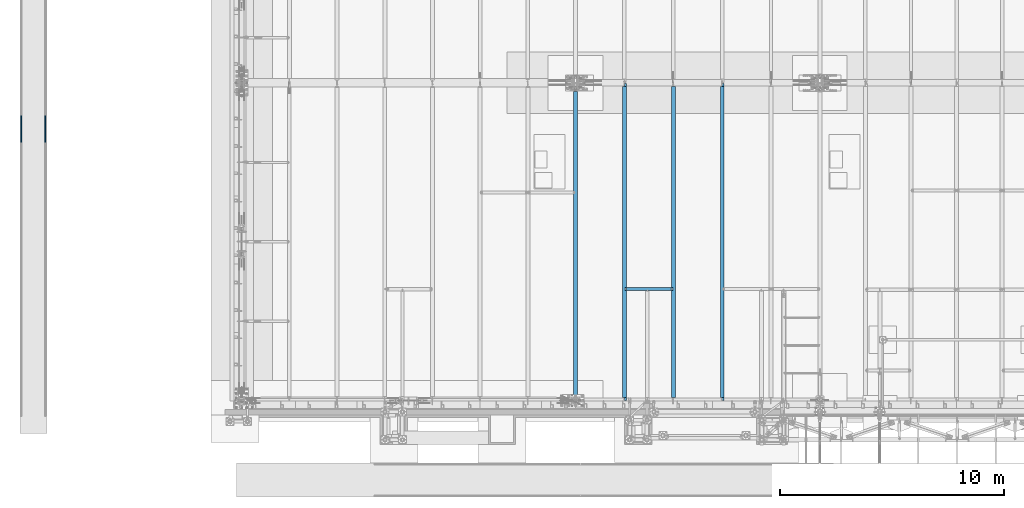
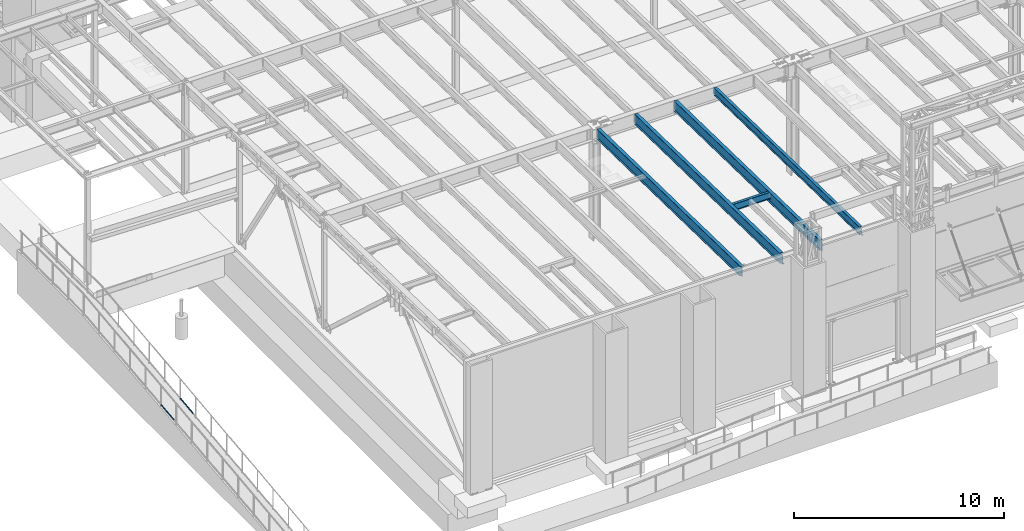
# One storey, part 1041 of 1763: 7 beams, 7 elements without a shape of their own.
"""IFC2X3 building model written with IfcOpenShell, lengths in millimetres."""

from ifc_helpers import new_model, si_unit, frame, origin_with_axes, place, context, subcontext, project, spatial, faceted_brep, material, type_object, element, aggregate, save


model = new_model("IFC2X3")

# Units and contexts
model_context = context("Model", 3, precision=1e-05, world=origin_with_axes())
body_context = subcontext(model_context, "Body", "Model", "MODEL_VIEW")
ifc_project = project(units=[si_unit("LENGTHUNIT", "METRE", prefix="MILLI"), si_unit("AREAUNIT", "SQUARE_METRE"), si_unit("VOLUMEUNIT", "CUBIC_METRE"), si_unit("MASSUNIT", "GRAM", prefix="KILO"), si_unit("TIMEUNIT", "SECOND"), si_unit("PLANEANGLEUNIT", "RADIAN"), si_unit("SOLIDANGLEUNIT", "STERADIAN"), si_unit("THERMODYNAMICTEMPERATUREUNIT", "DEGREE_CELSIUS"), si_unit("LUMINOUSINTENSITYUNIT", "LUMEN")], contexts=[model_context])

# Site, building, storey
site_placement = place(None, origin_with_axes())
site = spatial("IfcSite", under=ifc_project, at=site_placement, CompositionType="ELEMENT")
building_placement = place(site_placement, origin_with_axes())
building = spatial("IfcBuilding", under=site, at=building_placement, Name="Undefined", CompositionType="ELEMENT")
storey_placement = place(building_placement, origin_with_axes())
storey = spatial("IfcBuildingStorey", under=building, at=storey_placement, Name="Undefined", CompositionType="ELEMENT", Elevation=0.0)

# Assembly, beam
assembly_1_placement = place(storey_placement, origin_with_axes())
assembly_1 = element("IfcElementAssembly", 1, at=assembly_1_placement, inside=storey, Name="GUARDRAIL", AssemblyPlace="NOTDEFINED", PredefinedType="RIGID_FRAME")
ifc_material_1 = material(Name="STEEL/A513")
beam_type_1 = type_object("IfcBeamType", PredefinedType="NOTDEFINED")
beam_1_placement = place(assembly_1_placement, frame((-97200.6527017878, -2216.29390356327, 5028.74146606881), z_axis=(0.0, -0.114062593029902, 0.993473565260443), x_axis=(0.0, 0.993473565260443, 0.114062593029902)))
beam_1 = element("IfcBeam", 2, at=beam_1_placement, type_object=beam_type_1, material=ifc_material_1, Name="GUARDRAIL", context=body_context, shape_type="Brep", body=[
    faceted_brep([(1212.42937323828, -9.52499999999418, 16.49778394246), (1211.8517215474, -9.52499999999418, 11.466712380322), (1211.56648654196, -7.68349999999919, 13.3082123803215), (1209.73055642268, 0.0, 15.3670000003658), (1210.15342680948, 0.0, 19.0500000003658), (1211.56648654196, 7.68349999999919, 13.3082123803215), (1211.8517215474, 9.52499999999418, 11.466712380321), (1212.42937323828, 9.52499999999418, 16.49778394246), (1227.14132222466, 19.0500000000029, 3.70164343621582e-10), (1218.64737451707, 16.4977839420899, 9.52500000036889), (1216.4601138957, 16.4977839420899, -9.52499999963402), (1215.22541268888, 13.3082123799541, 7.68350000036753), (1216.41553116007, 15.3669999999984, 3.67435859516263e-10), (1213.46102245432, 13.3082123799541, -7.68349999963448), (1209.21857840355, 9.52499999999418, -11.4667123795907), (1208.64092671268, 9.52499999999418, -16.4977839417297), (1208.51047301132, 7.68349999999919, -13.3082123795912), (1206.20177595354, 0.0, -15.3669999996373), (1205.77890556675, 0.0, -19.0499999996364), (1209.21857840355, -9.52499999999418, -11.4667123795916), (1208.64092671268, -9.52499999999418, -16.4977839417297), (1208.51047301132, -7.68349999999919, -13.3082123795912), (1227.14132222466, -19.0500000000029, 3.71073838323355e-10), (1216.4601138957, -16.4977839420899, -9.52499999963402), (1218.64737451707, -16.4977839420899, 9.52500000036889), (1213.46102245432, -13.3082123799541, -7.68349999963448), (1216.41553116007, -15.3669999999984, 3.67435859516263e-10), (1215.22541268888, -13.3082123799541, 7.68350000036753), (0.0, -16.4977839420899, -9.52500000000146), (0.0, -9.52499999999418, -16.4977839420935), (1.45519152283669e-11, 1.81898940354586e-12, -19.0499999999993), (0.0, 9.52499999999418, -16.4977839420935), (0.0, 16.4977839420899, -9.52500000000146), (0.0, 19.0500000000029, 0.0), (0.0, 16.4977839420899, 9.52500000000146), (0.0, 9.52499999999418, 16.4977839420935), (1.45519152283669e-11, 1.81898940354586e-12, 19.0499999999993), (0.0, -9.52499999999418, 16.4977839420935), (0.0, -16.4977839420899, 9.52500000000146), (0.0, -19.0500000000029, 0.0), (3.63797880709171e-12, -13.3082123799541, -7.68349999999737), (3.63797880709171e-12, -7.68349999999919, -13.3082123799522), (3.63797880709171e-12, 0.0, -15.3669999999956), (3.63797880709171e-12, 7.68349999999919, -13.3082123799522), (3.63797880709171e-12, 13.3082123799541, -7.68349999999737), (4.71409293822944e-08, 15.3669999999984, 0.0), (-1.81898940354586e-12, 13.3082123799541, 7.68349999999919), (-3.63797880709171e-12, 7.68349999999919, 13.3082123799531), (-1.81898940354586e-12, 0.0, 15.3669999999966), (-3.63797880709171e-12, -7.68349999999919, 13.3082123799531), (-1.81898940354586e-12, -13.3082123799541, 7.68349999999919), (4.71409293822944e-08, -15.3669999999984, 0.0)], [[[0, 1, 2, 3, 4]], [[4, 3, 5, 6, 7]], [[8, 9, 10]], [[7, 6, 11, 12, 13, 14, 15, 10, 9]], [[16, 17, 18, 15, 14]], [[19, 20, 18, 17, 21]], [[22, 23, 24]], [[24, 23, 20, 19, 25, 26, 27, 1, 0]], [[28, 29, 20, 23]], [[29, 30, 18, 20]], [[30, 31, 15, 18]], [[31, 32, 10, 15]], [[32, 33, 8, 10]], [[33, 34, 9, 8]], [[34, 35, 7, 9]], [[35, 36, 4, 7]], [[36, 37, 0, 4]], [[37, 38, 24, 0]], [[38, 39, 22, 24]], [[39, 28, 23, 22]], [[38, 37, 36, 35, 34, 33, 32, 31, 30, 29, 28, 39], [40, 41, 42, 43, 44, 45, 46, 47, 48, 49, 50, 51]], [[40, 51, 26, 25]], [[21, 41, 40, 25, 19]], [[42, 41, 21, 17]], [[43, 42, 17, 16]], [[44, 43, 16, 14, 13]], [[45, 44, 13, 12]], [[46, 45, 12, 11]], [[5, 47, 46, 11, 6]], [[48, 47, 5, 3]], [[49, 48, 3, 2]], [[50, 49, 2, 1, 27]], [[51, 50, 27, 26]]]),
])
aggregate(assembly_1, [beam_1])

assembly_2_placement = place(storey_placement, origin_with_axes())
assembly_2 = element("IfcElementAssembly", 3, at=assembly_2_placement, inside=storey, Name="GUARDRAIL", AssemblyPlace="NOTDEFINED", PredefinedType="RIGID_FRAME")
beam_2_placement = place(assembly_2_placement, frame((-96133.8527017878, -2216.29390356327, 5028.74146606881), z_axis=(0.0, -0.114062593029902, 0.993473565260443), x_axis=(0.0, 0.993473565260443, 0.114062593029902)))
beam_2 = element("IfcBeam", 4, at=beam_2_placement, type_object=beam_type_1, material=ifc_material_1, Name="GUARDRAIL", context=body_context, shape_type="Brep", body=[
    faceted_brep([(1212.42937323828, -9.52499999999418, 16.49778394246), (1211.8517215474, -9.52499999999418, 11.466712380322), (1211.56648654196, -7.68349999999919, 13.3082123803215), (1209.73055642268, 0.0, 15.3670000003658), (1210.15342680948, 0.0, 19.0500000003658), (1211.56648654196, 7.68349999999919, 13.3082123803215), (1211.8517215474, 9.52499999999418, 11.466712380321), (1212.42937323828, 9.52499999999418, 16.49778394246), (1227.14132222466, 19.0500000000029, 3.70164343621582e-10), (1218.64737451707, 16.4977839420899, 9.52500000036889), (1216.4601138957, 16.4977839420899, -9.52499999963402), (1215.22541268888, 13.3082123799541, 7.68350000036753), (1216.41553116007, 15.3669999999984, 3.67435859516263e-10), (1213.46102245432, 13.3082123799541, -7.68349999963448), (1209.21857840355, 9.52499999999418, -11.4667123795907), (1208.64092671268, 9.52499999999418, -16.4977839417297), (1208.51047301132, 7.68349999999919, -13.3082123795912), (1206.20177595354, 0.0, -15.3669999996373), (1205.77890556675, 0.0, -19.0499999996364), (1209.21857840355, -9.52499999999418, -11.4667123795916), (1208.64092671268, -9.52499999999418, -16.4977839417297), (1208.51047301132, -7.68349999999919, -13.3082123795912), (1227.14132222466, -19.0500000000029, 3.71073838323355e-10), (1216.4601138957, -16.4977839420899, -9.52499999963402), (1218.64737451707, -16.4977839420899, 9.52500000036889), (1213.46102245432, -13.3082123799541, -7.68349999963448), (1216.41553116007, -15.3669999999984, 3.67435859516263e-10), (1215.22541268888, -13.3082123799541, 7.68350000036753), (0.0, -16.4977839420899, -9.52500000000146), (0.0, -9.52499999999418, -16.4977839420935), (1.45519152283669e-11, 1.81898940354586e-12, -19.0499999999993), (0.0, 9.52499999999418, -16.4977839420935), (0.0, 16.4977839420899, -9.52500000000146), (0.0, 19.0500000000029, 0.0), (0.0, 16.4977839420899, 9.52500000000146), (0.0, 9.52499999999418, 16.4977839420935), (1.45519152283669e-11, 1.81898940354586e-12, 19.0499999999993), (0.0, -9.52499999999418, 16.4977839420935), (0.0, -16.4977839420899, 9.52500000000146), (0.0, -19.0500000000029, 0.0), (3.63797880709171e-12, -13.3082123799541, -7.68349999999737), (3.63797880709171e-12, -7.68349999999919, -13.3082123799522), (3.63797880709171e-12, 0.0, -15.3669999999956), (3.63797880709171e-12, 7.68349999999919, -13.3082123799522), (3.63797880709171e-12, 13.3082123799541, -7.68349999999737), (4.71409293822944e-08, 15.3669999999984, 0.0), (-1.81898940354586e-12, 13.3082123799541, 7.68349999999919), (-3.63797880709171e-12, 7.68349999999919, 13.3082123799531), (-1.81898940354586e-12, 0.0, 15.3669999999966), (-3.63797880709171e-12, -7.68349999999919, 13.3082123799531), (-1.81898940354586e-12, -13.3082123799541, 7.68349999999919), (4.71409293822944e-08, -15.3669999999984, 0.0)], [[[0, 1, 2, 3, 4]], [[4, 3, 5, 6, 7]], [[8, 9, 10]], [[7, 6, 11, 12, 13, 14, 15, 10, 9]], [[16, 17, 18, 15, 14]], [[19, 20, 18, 17, 21]], [[22, 23, 24]], [[24, 23, 20, 19, 25, 26, 27, 1, 0]], [[28, 29, 20, 23]], [[29, 30, 18, 20]], [[30, 31, 15, 18]], [[31, 32, 10, 15]], [[32, 33, 8, 10]], [[33, 34, 9, 8]], [[34, 35, 7, 9]], [[35, 36, 4, 7]], [[36, 37, 0, 4]], [[37, 38, 24, 0]], [[38, 39, 22, 24]], [[39, 28, 23, 22]], [[38, 37, 36, 35, 34, 33, 32, 31, 30, 29, 28, 39], [40, 41, 42, 43, 44, 45, 46, 47, 48, 49, 50, 51]], [[40, 51, 26, 25]], [[21, 41, 40, 25, 19]], [[42, 41, 21, 17]], [[43, 42, 17, 16]], [[44, 43, 16, 14, 13]], [[45, 44, 13, 12]], [[46, 45, 12, 11]], [[5, 47, 46, 11, 6]], [[48, 47, 5, 3]], [[49, 48, 3, 2]], [[50, 49, 2, 1, 27]], [[51, 50, 27, 26]]]),
])
aggregate(assembly_2, [beam_2])

assembly_3_placement = place(storey_placement, origin_with_axes())
assembly_3 = element("IfcElementAssembly", 5, at=assembly_3_placement, inside=storey, Name="BEAM", AssemblyPlace="NOTDEFINED", PredefinedType="RIGID_FRAME")
ifc_material_2 = material(Name="STEEL/A992")
beam_type_2 = type_object("IfcBeamType", Name="W16X26", PredefinedType="NOTDEFINED")
beam_3_placement = place(assembly_3_placement, frame((-70311.7172736983, -8739.17542108259, 11900.629892136), z_axis=(0.0, 0.0, 1.0), x_axis=(1.0, 0.0, 0.0)))
beam_3 = element("IfcBeam", 6, at=beam_3_placement, type_object=beam_type_2, material=ifc_material_2, Name="BEAM", ObjectType="W16X26", context=body_context, shape_type="Brep", body=[
    faceted_brep([(2079.3075, -69.8500000000004, 200.025), (2079.3075, -69.8500000000004, 190.5), (2079.3075, -3.17499999999927, 190.5), (2079.3075, -3.17499999999927, 180.715001487702), (2079.3075, 3.17499999999927, 180.715001487702), (2079.3075, 3.17499999999927, 190.5), (2079.3075, 69.8500000000004, 190.5), (2079.3075, 69.8500000000004, 200.025), (2080.27422992259, -3.17499999999927, 175.854921969656), (2080.27422992259, 3.17499999999927, 175.854921969656), (2083.02724382306, -3.17499999999927, 171.734745501502), (2083.02724382306, 3.17499999999927, 171.734745501502), (2087.14742029121, -3.17499999999927, 168.981731601025), (2087.14742029121, 3.17499999999927, 168.981731601025), (2092.00749980926, -3.17499999999927, 168.015001678437), (2092.00749980926, 3.17499999999927, 168.015001678437), (2161.8575, -3.17499999999927, 168.015001678437), (2161.8575, 3.17499999999927, 168.015001678437), (100.012500000012, -69.8500000000004, 200.025), (100.012500000012, 69.8500000000004, 200.025), (100.012500000012, 69.8500000000004, 190.5), (100.012500000012, 3.17499999999927, 190.5), (100.012500000012, 3.17499999999927, 180.715001488035), (100.012500000012, -3.17499999999927, 180.715001488035), (100.012500000012, -3.17499999999927, 190.5), (100.012500000012, -69.8500000000004, 190.5), (99.0457700774205, 3.17499999999927, 175.854921969989), (99.0457700774205, -3.17499999999927, 175.854921969989), (96.2927561769466, 3.17499999999927, 171.734745501835), (96.2927561769466, -3.17499999999927, 171.734745501835), (92.1725797087929, 3.17499999999927, 168.981731601358), (92.1725797087929, -3.17499999999927, 168.981731601358), (87.3125001907465, 3.17499999999927, 168.01500167877), (87.3125001907465, -3.17499999999927, 168.01500167877), (17.4625000000087, 3.17499999999927, 168.01500167877), (17.4625000000087, -3.17499999999927, 168.01500167877), (17.4625000000087, 3.17499999999927, -190.5), (17.4625000000087, 69.8500000000004, -190.5), (17.4625000000087, 69.8500000000004, -200.025), (17.4625000000087, -69.8500000000004, -200.025), (17.4625000000087, -69.8500000000004, -190.5), (17.4625000000087, -3.17499999999927, -190.5), (2161.8575, 3.17499999999927, -190.5), (2161.8575, 69.8500000000004, -190.5), (2161.8575, 69.8500000000004, -200.025), (2161.8575, -69.8500000000004, -200.025), (2161.8575, -69.8500000000004, -190.5), (2161.8575, -3.17499999999927, -190.5)], [[[0, 1, 2, 3, 4, 5, 6, 7]], [[8, 9, 4, 3]], [[10, 11, 9, 8]], [[12, 13, 11, 10]], [[14, 15, 13, 12]], [[16, 17, 15, 14]], [[18, 19, 20, 21, 22, 23, 24, 25]], [[23, 22, 26, 27]], [[27, 26, 28, 29]], [[29, 28, 30, 31]], [[31, 30, 32, 33]], [[33, 32, 34, 35]], [[36, 37, 38, 39, 40, 41, 35, 34]], [[37, 36, 42, 43]], [[38, 37, 43, 44]], [[39, 38, 44, 45]], [[40, 39, 45, 46]], [[41, 40, 46, 47]], [[12, 10, 8, 3, 2, 24, 23, 27, 29, 31, 33, 35, 41, 47, 16, 14]], [[25, 24, 2, 1]], [[18, 25, 1, 0]], [[19, 18, 0, 7]], [[20, 19, 7, 6]], [[21, 20, 6, 5]], [[42, 36, 34, 32, 30, 28, 26, 22, 21, 5, 4, 9, 11, 13, 15, 17]], [[47, 46, 45, 44, 43, 42, 17, 16]]]),
])
aggregate(assembly_3, [beam_3])

assembly_4_placement = place(storey_placement, origin_with_axes())
assembly_4 = element("IfcElementAssembly", 7, at=assembly_4_placement, inside=storey, Name="BEAM", AssemblyPlace="NOTDEFINED", PredefinedType="RIGID_FRAME")
beam_type_3 = type_object("IfcBeamType", Name="W18X35", PredefinedType="NOTDEFINED")
beam_4_placement = place(assembly_4_placement, frame((-65953.0772736983, -13720.7116289294, 11979.324245716), z_axis=(0.0, 0.0209013539966291, 0.999781542838788), x_axis=(0.0, 0.999781542776098, -0.0209013569953182)))
beam_4 = element("IfcBeam", 8, at=beam_4_placement, type_object=beam_type_3, material=ifc_material_2, Name="BEAM", ObjectType="W18X35", context=body_context, shape_type="Brep", body=[
    faceted_brep([(151.560935824949, 4.2686672599084, -214.31250000022), (151.56093582492, 4.26882967424172, -225.425000000228), (29.273643525974, 4.2688137767982, -225.42500000019), (29.0413264561339, 4.26865133224055, -214.31250000018), (151.560926473738, 76.1999999999971, -214.312500000222), (151.560926473736, 76.1999999999971, -225.425000000228), (151.560925824304, 3.96875, 214.312500000124), (151.560925824304, 76.1999999999971, 214.312500000124), (14015.1114866801, 76.1999999999971, 214.312499995558), (14015.1114866801, 3.96875, 214.312499995558), (151.560925824308, -76.1999999999971, 225.425000000132), (151.560925824308, 76.1999999999971, 225.425000000132), (151.560925824293, 3.96875, 187.065001487916), (151.560925824293, -3.96875, 187.065001487916), (151.560925824304, -3.96875, 214.312500000124), (151.560925824304, -76.1999999999971, 214.312500000124), (150.594195901702, 3.96875, 182.204921969858), (150.594195901702, -3.96875, 182.204921969858), (147.841182001217, 3.96875, 178.084745501696), (147.841182001217, -3.96875, 178.084745501696), (143.721005533052, 3.96875, 175.331731601214), (143.721005533052, -3.96875, 175.331731601214), (138.860926014993, 3.96875, 174.365001678625), (138.860926014993, -3.96875, 174.365001678625), (20.915664516624, 3.96875, 174.365001678663), (20.915664516624, -3.96875, 174.365001678663), (29.0413264561339, -3.96875, -214.31250000018), (29.0413264561339, -76.1999999999971, -214.31250000018), (14165.6418872877, -76.1999999999971, -214.312500004837), (14165.6418872877, -3.96875, -214.312500004837), (29.273643525974, -76.1999999999971, -225.42500000019), (14165.8742043575, -76.1999999999971, -225.425000004847), (14015.111475978, 4.2688297624336, -214.312500004788), (14015.111475978, 4.26866734583018, -225.425000004798), (14015.1114709427, 76.1999999999971, -225.425000004796), (14015.1114709427, 76.1999999999971, -214.312500004788), (14165.6418872877, 4.26875000000291, -214.312500004837), (14165.6627009912, 4.26875000000291, -215.308088836937), (14064.0848962425, 4.26875000000291, -217.431666606117), (14064.0196871856, 4.26875000000291, -214.312500004802), (14165.8742043575, 4.26867789952666, -225.425000004847), (14165.6418872877, 3.96875, -214.312500004837), (14157.6489780418, 3.96875, 168.014997741), (14157.6489780418, -3.96875, 168.014997741), (14022.9514069713, -3.96875, 168.981727663589), (14018.8312305032, -3.96875, 171.734741564072), (14016.0782166027, -3.96875, 175.854918032239), (14015.1114866801, -3.96875, 180.714997550294), (14015.1114866801, -3.96875, 214.312499995558), (14027.8114864894, -3.96875, 168.014997740998), (14015.1114866801, -76.1999999999971, 214.312499995558), (14015.1114866801, -76.1999999999971, 225.424999995566), (14015.1114866801, 76.1999999999971, 225.424999995566), (14015.1114866801, 3.96875, 180.714997550294), (14016.0782166027, 3.96875, 175.854918032239), (14018.8312305032, 3.96875, 171.734741564072), (14022.9514069713, 3.96875, 168.981727663589), (14027.8114864894, 3.96875, 168.014997740998), (29.0413264561339, 3.96875, -214.31250000018)], [[[0, 1, 2, 3]], [[4, 5, 1, 0]], [[6, 7, 8, 9]], [[10, 11, 7, 6, 12, 13, 14, 15]], [[13, 12, 16, 17]], [[17, 16, 18, 19]], [[19, 18, 20, 21]], [[21, 20, 22, 23]], [[23, 22, 24, 25]], [[26, 27, 28, 29]], [[27, 30, 31, 28]], [[32, 33, 34, 35]], [[36, 37, 38, 39]], [[37, 40, 33, 32, 39, 38]], [[36, 41, 42, 43, 29, 28, 31, 40, 37]], [[44, 45, 46, 47, 48, 14, 13, 17, 19, 21, 23, 25, 26, 29, 43, 49]], [[15, 14, 48, 50]], [[10, 15, 50, 51]], [[11, 10, 51, 52]], [[7, 11, 52, 8]], [[51, 50, 48, 47, 53, 9, 8, 52]], [[46, 54, 53, 47]], [[45, 55, 54, 46]], [[44, 56, 55, 45]], [[49, 57, 56, 44]], [[43, 42, 57, 49]], [[41, 58, 24, 22, 20, 18, 16, 12, 6, 9, 53, 54, 55, 56, 57, 42]], [[30, 27, 26, 25, 24, 58, 3, 2]], [[34, 33, 40, 31, 30, 2, 1, 5]], [[35, 34, 5, 4]], [[58, 41, 36, 39, 32, 35, 4, 0, 3]]]),
])
aggregate(assembly_4, [beam_4])

assembly_5_placement = place(storey_placement, origin_with_axes())
assembly_5 = element("IfcElementAssembly", 9, at=assembly_5_placement, inside=storey, Name="BEAM", AssemblyPlace="NOTDEFINED", PredefinedType="RIGID_FRAME")
beam_type_4 = type_object("IfcBeamType", Name="W24X55", PredefinedType="NOTDEFINED")
beam_5_placement = place(assembly_5_placement, frame((-68132.3972736983, -13722.2711313756, 11904.7280453544), z_axis=(0.0, 0.0209013539966291, 0.999781542838788), x_axis=(0.0, 0.999781542776098, -0.0209013569953182)))
beam_5 = element("IfcBeam", 10, at=beam_5_placement, type_object=beam_type_4, material=ifc_material_2, Name="BEAM", ObjectType="W24X55", context=body_context, shape_type="Brep", body=[
    faceted_brep([(14016.593893803, 4.76249999999709, -287.337500004851), (14016.593893803, 4.76238284193096, -300.037500004859), (14016.5938910267, 88.9000000000015, -300.037500004861), (14016.5938910267, 88.9000000000015, -287.337500004851), (14118.1827906951, 4.76299991607812, -300.037500004893), (14117.9172854725, 4.76249999999709, -287.337500004882), (165.102558712022, -4.76249999999709, -287.337500000289), (165.102558712022, -88.9000000000015, -287.337500000289), (14016.5938907292, -88.9000000000015, -287.337500004849), (14016.5938879523, -4.76249999999709, -287.337500004849), (153.198208143893, 4.76249999999709, 287.33750000018), (153.198208143893, 88.9000000000015, 287.33750000018), (14016.5938908944, 88.9000000000015, 287.33749999561), (14016.5938908944, 4.76249999999709, 287.33749999561), (153.198208143898, -88.9000000000015, 300.037500000191), (153.198208143898, 88.9000000000015, 300.037500000191), (153.198208143884, 4.76249999999709, 261.937499809663), (153.198208143884, -4.76249999999709, 261.937499809663), (153.198208143893, -4.76249999999709, 287.33750000018), (153.198208143893, -88.9000000000015, 287.33750000018), (152.50805080805, -4.76249999999709, 258.467844579442), (152.231478221292, 4.76249999999709, 257.077420291605), (152.231478221292, -4.76249999999709, 257.077420291605), (149.478464320808, 4.76249999999709, 252.957243823441), (149.478464320808, -4.76249999999709, 252.957243823441), (145.358287852643, 4.76249999999709, 250.204229922958), (145.358287852643, -4.76249999999709, 250.204229922958), (140.498208334584, 4.76249999999709, 249.237500000372), (140.498208334584, -4.76249999999709, 249.237500000372), (20.9102290337687, 4.76249999999709, 249.23750000041), (20.9102290337687, -4.76249999999709, 249.23750000041), (31.9459431613013, 4.76249999999709, -278.637500001068), (31.9459431613013, -4.76249999999709, -278.637500001068), (153.198208334481, 4.76249999999709, -278.637500001108), (153.198208334481, -4.76249999999709, -278.637500001108), (158.058287852537, 4.76249999999709, -279.6042299237), (158.058287852537, -4.76249999999709, -279.6042299237), (162.178464320699, 4.76249999999709, -282.357243824186), (162.178464320699, -4.76249999999709, -282.357243824186), (163.867339899425, -4.76249999999709, -284.884824747733), (164.93147822118, 4.76249999999709, -286.477420292351), (164.93147822118, -4.76249999999709, -286.477420292351), (165.102558712022, 4.76249999999709, -287.337500000289), (165.102558712022, 88.9000000000015, -287.337500000289), (165.89820814377, 88.9000000000015, -291.337499810408), (165.89820814377, -88.9000000000015, -291.337499810408), (165.898208143768, 88.9000000000015, -300.037500000297), (165.898208143768, -88.9000000000015, -300.037500000297), (14016.5938907292, -88.9000000000015, -300.037500004861), (14016.5938879524, -4.76262320829846, -300.037500004861), (14118.182790722, -4.76200008393062, -300.037500004893), (14117.9172854725, -4.76249999999709, -287.337500004882), (14168.9938907729, -4.76200008393062, -300.03750000491), (14168.7283855234, -4.76249999999709, -287.3375000049), (14168.993890746, 4.76299991607812, -300.03750000491), (14168.7283855234, 4.76249999999709, -287.3375000049), (14168.3301609801, -4.76249999999709, -268.289092414178), (14168.3301647496, 4.76249999999709, -268.289272721053), (14157.6435424792, 4.76249999999709, 242.887499877306), (14157.6435424792, -4.76249999999709, 242.887499877306), (14024.4338111857, -4.76249999999709, 243.854229799896), (14020.3136347175, -4.76249999999709, 246.607243700379), (14017.560620817, -4.76249999999709, 250.727420168543), (14016.5938908944, -4.76249999999709, 255.5874996866), (14016.5938908944, -4.76249999999709, 287.33749999561), (14029.2938907037, -4.76249999999709, 242.887499877303), (14016.5938908944, -88.9000000000015, 287.33749999561), (14016.5938908944, -88.9000000000015, 300.037499995622), (14016.5938908944, 88.9000000000015, 300.037499995622), (14016.5938908944, 4.76249999999709, 255.5874996866), (14017.560620817, 4.76249999999709, 250.727420168543), (14020.3136347175, 4.76249999999709, 246.607243700379), (14024.4338111857, 4.76249999999709, 243.854229799896), (14029.2938907037, 4.76249999999709, 242.887499877303)], [[[0, 1, 2, 3]], [[4, 1, 0, 5]], [[6, 7, 8, 9]], [[10, 11, 12, 13]], [[14, 15, 11, 10, 16, 17, 18, 19]], [[20, 17, 16, 21, 22]], [[22, 21, 23, 24]], [[24, 23, 25, 26]], [[26, 25, 27, 28]], [[28, 27, 29, 30]], [[30, 29, 31, 32]], [[32, 31, 33, 34]], [[34, 33, 35, 36]], [[36, 35, 37, 38]], [[39, 38, 37, 40, 41]], [[7, 6, 41, 40, 42, 43, 44, 45]], [[45, 44, 46, 47]], [[7, 45, 47, 48, 8]], [[8, 48, 49, 9]], [[50, 51, 9, 49]], [[52, 53, 51, 50]], [[54, 4, 5, 55]], [[56, 53, 52, 54, 55, 57, 58, 59]], [[60, 61, 62, 63, 64, 18, 17, 20, 22, 24, 26, 28, 30, 32, 34, 36, 38, 39, 41, 6, 9, 51, 53, 56, 59, 65]], [[19, 18, 64, 66]], [[14, 19, 66, 67]], [[15, 14, 67, 68]], [[11, 15, 68, 12]], [[67, 66, 64, 63, 69, 13, 12, 68]], [[62, 70, 69, 63]], [[61, 71, 70, 62]], [[60, 72, 71, 61]], [[65, 73, 72, 60]], [[59, 58, 73, 65]], [[57, 55, 5, 0, 42, 40, 37, 35, 33, 31, 29, 27, 25, 23, 21, 16, 10, 13, 69, 70, 71, 72, 73, 58]], [[43, 42, 0, 3]], [[46, 44, 43, 3, 2]], [[54, 52, 50, 49, 48, 47, 46, 2, 1, 4]]]),
])
aggregate(assembly_5, [beam_5])

assembly_6_placement = place(storey_placement, origin_with_axes())
assembly_6 = element("IfcElementAssembly", 11, at=assembly_6_placement, inside=storey, Name="BEAM", AssemblyPlace="NOTDEFINED", PredefinedType="RIGID_FRAME")
beam_6_placement = place(assembly_6_placement, frame((-70311.7172736983, -13722.2711313756, 11904.7280453544), z_axis=(0.0, 0.0209013539966291, 0.999781542838788), x_axis=(0.0, 0.999781542776098, -0.0209013569953182)))
beam_6 = element("IfcBeam", 12, at=beam_6_placement, type_object=beam_type_4, material=ifc_material_2, Name="BEAM", ObjectType="W24X55", context=body_context, shape_type="Brep", body=[
    faceted_brep([(14016.6713189086, 5.06262333965424, -287.337500004851), (14016.6713189087, 5.06237371335737, -300.037500004863), (14016.6713136267, 88.9000000000015, -300.037500004863), (14016.6713136267, 88.9000000000015, -287.337500004851), (14168.9938907462, 5.06238331007626, -300.03750000491), (14168.7283855236, 5.06263291966025, -287.3375000049), (153.120769029569, 4.76249999999709, 287.33750000018), (153.120769029569, 88.9000000000015, 287.33750000018), (14016.6713298856, 88.9000000000015, 287.33749999561), (14016.6713298856, 4.76249999999709, 287.33749999561), (153.120769029574, -88.9000000000015, 300.03750000019), (153.120769029574, 88.9000000000015, 300.03750000019), (153.12076902956, 4.76249999999709, 261.67750148814), (153.12076902956, -4.76249999999709, 261.67750148814), (153.120769029569, -4.76249999999709, 287.33750000018), (153.120769029569, -88.9000000000015, 287.33750000018), (152.15403910697, 4.76249999999709, 256.817421970085), (152.15403910697, -4.76249999999709, 256.817421970085), (149.401025206482, 4.76249999999709, 252.697245501922), (149.401025206482, -4.76249999999709, 252.697245501922), (145.280848738317, 4.76249999999709, 249.944231601437), (145.280848738317, -4.76249999999709, 249.944231601437), (140.42076922026, 4.76249999999709, 248.977501678848), (140.42076922026, -4.76249999999709, 248.977501678848), (20.9156645386702, 4.76249999999709, 248.977501678888), (20.9156645386702, -4.76249999999709, 248.977501678888), (32.1278246917773, -4.76249999999709, -287.337500000243), (32.1278246917773, -88.9000000000015, -287.337500000243), (14168.7283855236, -88.9000000000015, -287.3375000049), (14168.7283855234, -4.76249999999709, -287.3375000049), (14024.5112501769, -4.76249999999709, 243.594227663818), (14020.3910737087, -4.76249999999709, 246.347241564303), (14017.6380598082, -4.76249999999709, 250.467418032464), (14016.6713298856, -4.76249999999709, 255.327497550523), (14016.6713298856, -4.76249999999709, 287.33749999561), (14157.648978064, -4.76249999999709, 242.627497741229), (14029.3713296949, -4.76249999999709, 242.627497741227), (14016.6713298856, -88.9000000000015, 287.33749999561), (14016.6713298856, -88.9000000000015, 300.03749999562), (14016.6713298856, 88.9000000000015, 300.03749999562), (14016.6713298856, 4.76249999999709, 255.327497550523), (14017.6380598082, 4.76249999999709, 250.467418032464), (14020.3910737087, 4.76249999999709, 246.347241564303), (14024.5112501769, 4.76249999999709, 243.594227663818), (14029.3713296949, 4.76249999999709, 242.627497741227), (14157.648978064, 4.76249999999709, 242.627497741229), (14168.7283855234, 4.76249999999709, -287.3375000049), (32.1278246917773, 4.76249999999709, -287.337500000243), (153.120588301108, 88.9000000000015, -287.337500000282), (153.120588301104, 88.9000000000015, -300.037500000293), (153.120599954549, 5.06262326912838, -300.037500000293), (153.120599954584, 5.06237364569824, -287.337500000282), (32.3933299144519, 5.06260648809985, -300.037500000253), (32.1278246917773, 5.06235682772967, -287.337500000243), (32.3933299144519, -88.9000000000015, -300.037500000253), (14168.9938907462, -88.9000000000015, -300.03750000491)], [[[0, 1, 2, 3]], [[4, 1, 0, 5]], [[6, 7, 8, 9]], [[10, 11, 7, 6, 12, 13, 14, 15]], [[13, 12, 16, 17]], [[17, 16, 18, 19]], [[19, 18, 20, 21]], [[21, 20, 22, 23]], [[23, 22, 24, 25]], [[26, 27, 28, 29]], [[30, 31, 32, 33, 34, 14, 13, 17, 19, 21, 23, 25, 26, 29, 35, 36]], [[15, 14, 34, 37]], [[10, 15, 37, 38]], [[11, 10, 38, 39]], [[7, 11, 39, 8]], [[38, 37, 34, 33, 40, 9, 8, 39]], [[32, 41, 40, 33]], [[31, 42, 41, 32]], [[30, 43, 42, 31]], [[36, 44, 43, 30]], [[35, 45, 44, 36]], [[46, 47, 24, 22, 20, 18, 16, 12, 6, 9, 40, 41, 42, 43, 44, 45]], [[48, 49, 50, 51]], [[51, 50, 52, 53]], [[54, 27, 26, 25, 24, 47, 53, 52]], [[27, 54, 55, 28]], [[46, 45, 35, 29, 28, 55, 4, 5]], [[3, 48, 51, 53, 47, 46, 5, 0]], [[49, 48, 3, 2]], [[55, 54, 52, 50, 49, 2, 1, 4]]]),
])
aggregate(assembly_6, [beam_6])

assembly_7_placement = place(storey_placement, origin_with_axes())
assembly_7 = element("IfcElementAssembly", 13, at=assembly_7_placement, inside=storey, Name="BEAM", AssemblyPlace="NOTDEFINED", PredefinedType="RIGID_FRAME")
beam_7_placement = place(assembly_7_placement, frame((-72491.0372736984, -13722.2711313756, 11904.7280453544), z_axis=(0.0, 0.0209013539966291, 0.999781542838788), x_axis=(0.0, 0.999781542776098, -0.0209013569953182)))
beam_7 = element("IfcBeam", 14, at=beam_7_placement, type_object=beam_type_4, material=ifc_material_2, Name="BEAM", ObjectType="W24X55", context=body_context, shape_type="Brep", body=[
    faceted_brep([(240.904527849169, 4.76250305173744, -287.337500000313), (240.904527849165, 4.76250305173744, -300.037500000321), (126.870037648992, 4.76250305175927, -300.037500000284), (126.604532426318, 4.76249999999709, -287.337500000274), (240.904527849165, 88.8999999999942, -287.337500000313), (240.904527849165, 88.8999999999942, -300.037500000321), (114.590421100289, 4.76249999999709, 287.337500000192), (114.590421100289, 88.9000000000015, 287.337500000192), (13798.3437883337, 88.9000000000015, 287.337499995683), (13798.3437883337, 4.76249999999709, 287.337499995683), (13798.3437832867, -88.9000000000015, -287.33750000478), (13798.3436986942, -5.06238682331605, -287.337500004778), (13956.750841961, -5.06222699052159, -287.337500004831), (13956.750841961, -4.76249999999709, -287.337500004831), (240.904527849156, -4.76249999999709, -287.337500000311), (240.904527849156, -88.8999969482247, -287.337500000311), (126.604532426318, -4.76249999999709, -287.337500000274), (126.870037648992, -4.76250305176654, -300.037500000284), (240.904527849154, -4.76249999998254, -300.037500000321), (240.904527849152, -88.8999999999942, -300.037500000321), (13798.3437832867, -88.9000000000015, -300.03750000479), (13798.3436986944, -5.06261010107119, -300.03750000479), (13957.0163470948, -5.0624500003687, -300.037500004843), (13798.3437040695, 5.06261013302719, -287.337500004778), (13798.3437040698, 5.06238685527933, -300.037500004788), (13798.3436194776, 88.8999999999942, -300.03750000479), (13798.3436194776, 88.8999999999942, -287.337500004778), (13957.0163470948, 5.06254696322867, -300.037500004843), (13956.750841961, 5.06276997307577, -287.337500004831), (13956.750841961, 4.76249999999709, -287.337500004831), (13945.5386855639, 4.76249999999709, 248.97750166974), (13945.5386855639, -4.76249999999709, 248.97750166974), (13806.183708625, -4.76249999999709, 249.944231592328), (13802.0635321568, -4.76249999999709, 252.697245492813), (13799.3105182563, -4.76249999999709, 256.817421960977), (13798.3437883337, -4.76249999999709, 261.677501479031), (13798.3437883337, -4.76249999999709, 287.337499995683), (114.590421100289, -4.76249999999709, 287.337500000192), (13811.043788143, -4.76249999999709, 248.977501669737), (114.590421100289, -88.9000000000015, 287.337500000192), (13798.3437883337, -88.9000000000015, 287.337499995683), (114.324915877614, -88.9000000000015, 300.0375000002), (13798.3437883337, -88.9000000000015, 300.037499995693), (114.324915877614, 88.9000000000015, 300.0375000002), (13798.3437883337, 88.9000000000015, 300.037499995693), (13798.3437883337, 4.76249999999709, 261.677501479031), (13799.3105182563, 4.76249999999709, 256.817421960977), (13802.0635321568, 4.76249999999709, 252.697245492813), (13806.183708625, 4.76249999999709, 249.944231592328), (13811.043788143, 4.76249999999709, 248.977501669737), (121.060985559308, 4.76249999999709, -22.1711710599902), (120.264233260747, 4.76249999999709, 15.940147767602)], [[[0, 1, 2, 3]], [[4, 5, 1, 0]], [[6, 7, 8, 9]], [[10, 11, 12, 13, 14, 15]], [[16, 17, 18, 14]], [[15, 14, 18, 19]], [[20, 10, 15, 19]], [[10, 20, 21, 11]], [[22, 12, 11, 21]], [[23, 24, 25, 26]], [[27, 24, 23, 28]], [[29, 30, 31, 13, 12, 22, 27, 28]], [[32, 33, 34, 35, 36, 37, 16, 14, 13, 31, 38]], [[39, 37, 36, 40]], [[41, 39, 40, 42]], [[43, 41, 42, 44]], [[7, 43, 44, 8]], [[42, 40, 36, 35, 45, 9, 8, 44]], [[34, 46, 45, 35]], [[33, 47, 46, 34]], [[32, 48, 47, 33]], [[38, 49, 48, 32]], [[31, 30, 49, 38]], [[29, 0, 3, 50, 51, 6, 9, 45, 46, 47, 48, 49, 30]], [[17, 16, 37, 39, 41, 43, 7, 6, 51, 50, 3, 2]], [[25, 24, 27, 22, 21, 20, 19, 18, 17, 2, 1, 5]], [[26, 25, 5, 4]], [[29, 28, 23, 26, 4, 0]]]),
])
aggregate(assembly_7, [beam_7])

save(model, "model.ifc")
